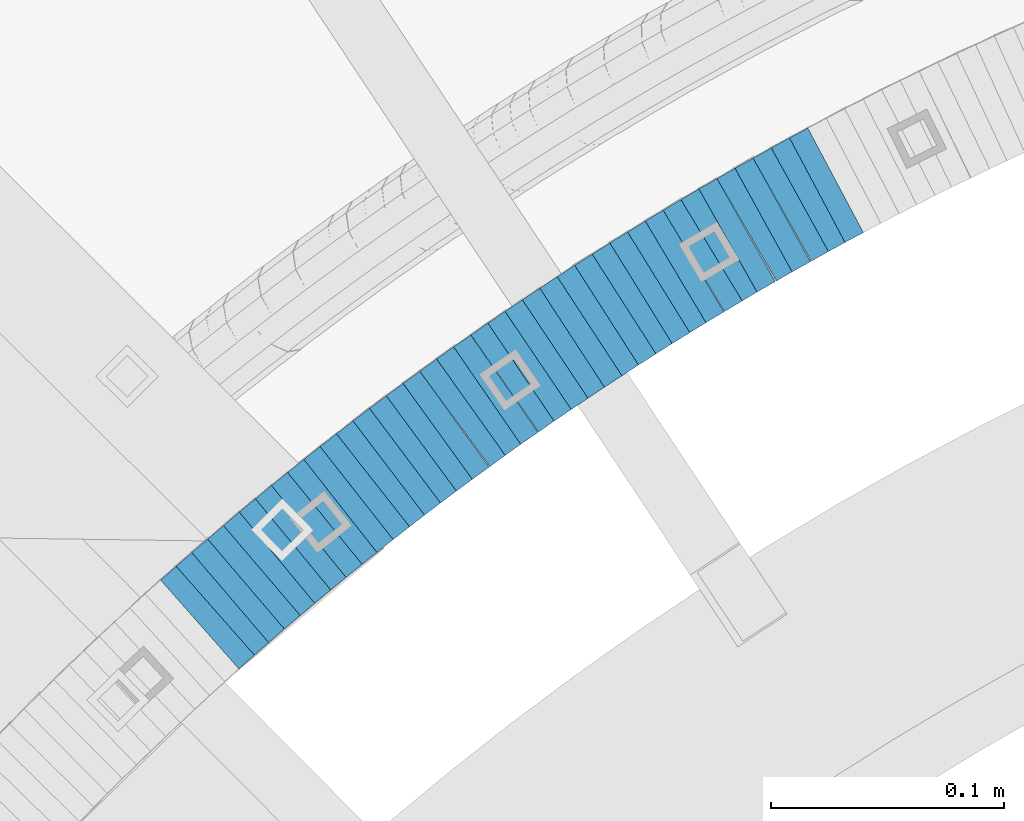
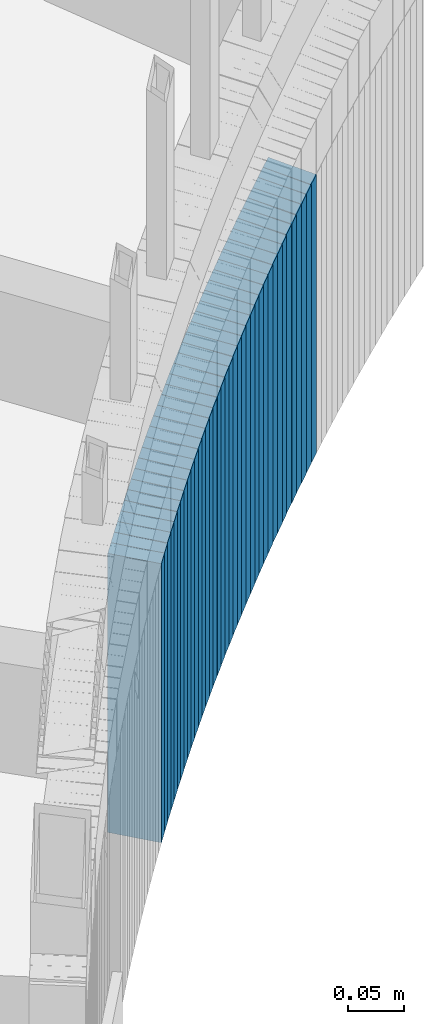
# One storey, part 897 of 975: 38 plates.
"""IFC2X3 building model written with IfcOpenShell, lengths in millimetres."""

from ifc_helpers import new_model, si_unit, frame, origin_with_axes, place, context, subcontext, project, spatial, faceted_brep, material, type_object, element, save


model = new_model("IFC2X3")

# Units and contexts
model_context = context("Model", 3, precision=1e-05, world=origin_with_axes())
body_context = subcontext(model_context, "Body", "Model", "MODEL_VIEW")
ifc_project = project(units=[si_unit("LENGTHUNIT", "METRE", prefix="MILLI"), si_unit("AREAUNIT", "SQUARE_METRE"), si_unit("VOLUMEUNIT", "CUBIC_METRE"), si_unit("MASSUNIT", "GRAM", prefix="KILO"), si_unit("TIMEUNIT", "SECOND"), si_unit("PLANEANGLEUNIT", "RADIAN"), si_unit("SOLIDANGLEUNIT", "STERADIAN"), si_unit("THERMODYNAMICTEMPERATUREUNIT", "DEGREE_CELSIUS"), si_unit("LUMINOUSINTENSITYUNIT", "LUMEN")], contexts=[model_context])

# Site, building, storey
site_placement = place(None, origin_with_axes())
site = spatial("IfcSite", under=ifc_project, at=site_placement, CompositionType="ELEMENT")
building_placement = place(site_placement, origin_with_axes())
building = spatial("IfcBuilding", under=site, at=building_placement, Name="Undefined", CompositionType="ELEMENT")
storey_placement = place(building_placement, origin_with_axes())
storey = spatial("IfcBuildingStorey", under=building, at=storey_placement, Name="Undefined", CompositionType="ELEMENT", Elevation=0.0)

# Plates
ifc_material = material(Name="STEEL/A36")
plate_type = type_object("IfcPlateType", PredefinedType="NOTDEFINED")
plate_1_placement = place(storey_placement, frame((34068.6990229387, 4631.93009048656, 613.700000000799), z_axis=(0.882970965834001, 0.469427601973053, -3.50903519574786e-11), x_axis=(0.0, 0.0, -1.0)))
element("IfcPlate", 1, at=plate_1_placement, inside=storey, type_object=plate_type, material=ifc_material, Name="WALL", context=body_context, shape_type="Brep", body=[
    faceted_brep([(0.0, -25.3999999999724, -1.81898940354586e-11), (-5.69999980926514, -25.4000000000451, 8.94986057279493), (-5.69999980926514, 25.3999999999942, 8.94986057280948), (0.0, 25.3999999999869, 1.45519152283669e-11), (299.100006103516, -25.4000000000451, 8.94986057279493), (299.100006103516, 25.3999999999942, 8.94986057280948), (304.799987792969, -25.3999999999724, -1.81898940354586e-11), (304.799987792969, 25.3999999999869, 1.45519152283669e-11)], [[[0, 1, 2, 3]], [[1, 4, 5, 2]], [[4, 6, 7, 5]], [[6, 0, 3, 7]], [[5, 7, 3, 2]], [[6, 4, 1, 0]]]),
])
plate_2_placement = place(storey_placement, frame((34061.2381867776, 4627.8137217421, 608.000000000803), z_axis=(0.875741388818649, 0.482780509041101, -7.90664671512786e-11), x_axis=(0.0, 0.0, -1.0)))
element("IfcPlate", 2, at=plate_2_placement, inside=storey, type_object=plate_type, material=ifc_material, Name="WALL", context=body_context, shape_type="Brep", body=[
    faceted_brep([(0.0, -25.3999999999724, -1.81898940354586e-11), (-5.69999980926514, -25.400000000096, 8.9140338897214), (-5.69999980926514, 25.4000000000524, 8.91403388979779), (0.0, 25.3999999999869, 1.45519152283669e-11), (299.100006103516, -25.400000000096, 8.9140338897214), (299.100006103516, 25.4000000000524, 8.91403388979779), (304.799987792969, -25.3999999999724, -1.81898940354586e-11), (304.799987792969, 25.3999999999869, 1.45519152283669e-11)], [[[0, 1, 2, 3]], [[1, 4, 5, 2]], [[4, 6, 7, 5]], [[6, 0, 3, 7]], [[5, 7, 3, 2]], [[6, 4, 1, 0]]]),
])
plate_3_placement = place(storey_placement, frame((34053.6551199948, 4623.53469993824, 602.200000000807), z_axis=(0.870978467909843, 0.491321186636015, 1.7358570403303e-10), x_axis=(0.0, 0.0, -1.0)))
element("IfcPlate", 3, at=plate_3_placement, inside=storey, type_object=plate_type, material=ifc_material, Name="WALL", context=body_context, shape_type="Brep", body=[
    faceted_brep([(0.0, -25.3999999999724, -1.81898940354586e-11), (-5.80000019073486, -25.3999999999396, 8.9627008438656), (-5.80000019073486, 25.3999999999178, 8.96270084374191), (0.0, 25.3999999999869, 1.45519152283669e-11), (299.0, -25.3999999999396, 8.9627008438656), (299.0, 25.3999999999178, 8.96270084374191), (304.799987792969, -25.3999999999724, -1.81898940354586e-11), (304.799987792969, 25.3999999999869, 1.45519152283669e-11)], [[[0, 1, 2, 3]], [[1, 4, 5, 2]], [[4, 6, 7, 5]], [[6, 0, 3, 7]], [[5, 7, 3, 2]], [[6, 4, 1, 0]]]),
])
plate_4_placement = place(storey_placement, frame((34045.638186776, 4619.113721742, 596.500000000813), z_axis=(0.875741388818649, 0.482780509041101, -7.90664671512786e-11), x_axis=(0.0, 0.0, -1.0)))
element("IfcPlate", 4, at=plate_4_placement, inside=storey, type_object=plate_type, material=ifc_material, Name="WALL", context=body_context, shape_type="Brep", body=[
    faceted_brep([(0.0, -25.3999999999724, -1.81898940354586e-11), (-5.69999980926514, -25.400000000096, 8.9140338897214), (-5.69999980926514, 25.4000000000524, 8.91403388979779), (0.0, 25.3999999999869, 1.45519152283669e-11), (299.100006103516, -25.400000000096, 8.9140338897214), (299.100006103516, 25.4000000000524, 8.91403388979779), (304.799987792969, -25.3999999999724, -1.81898940354586e-11), (304.799987792969, 25.3999999999869, 1.45519152283669e-11)], [[[0, 1, 2, 3]], [[1, 4, 5, 2]], [[4, 6, 7, 5]], [[6, 0, 3, 7]], [[5, 7, 3, 2]], [[6, 4, 1, 0]]]),
])
plate_5_placement = place(storey_placement, frame((34038.4915895317, 4614.92790563646, 590.800000000816), z_axis=(0.863371944159825, 0.504568019237926, -8.114466254483e-11), x_axis=(0.0, 0.0, -1.0)))
element("IfcPlate", 5, at=plate_5_placement, inside=storey, type_object=plate_type, material=ifc_material, Name="WALL", context=body_context, shape_type="Brep", body=[
    faceted_brep([(0.0, -25.3999999999724, -1.81898940354586e-11), (-5.69999980926514, -25.3999999999724, 8.91964149478372), (-5.69999980926514, 25.400000000016, 8.9196414947528), (0.0, 25.3999999999869, 1.45519152283669e-11), (299.100006103516, -25.3999999999724, 8.91964149478372), (299.100006103516, 25.400000000016, 8.9196414947528), (304.799987792969, -25.3999999999724, -1.81898940354586e-11), (304.799987792969, 25.3999999999869, 1.45519152283669e-11)], [[[0, 1, 2, 3]], [[1, 4, 5, 2]], [[4, 6, 7, 5]], [[6, 0, 3, 7]], [[5, 7, 3, 2]], [[6, 4, 1, 0]]]),
])
plate_6_placement = place(storey_placement, frame((34030.3551199954, 4610.33469993811, 585.100000000822), z_axis=(0.870978467909843, 0.491321186636015, 1.7358570403303e-10), x_axis=(0.0, 0.0, -1.0)))
element("IfcPlate", 6, at=plate_6_placement, inside=storey, type_object=plate_type, material=ifc_material, Name="WALL", context=body_context, shape_type="Brep", body=[
    faceted_brep([(0.0, -25.3999999999724, -1.81898940354586e-11), (-5.69999980926514, -25.4000000000087, 8.9643735885511), (-5.69999980926514, 25.4000000000669, 8.96437358860567), (0.0, 25.3999999999869, 1.45519152283669e-11), (299.100006103516, -25.4000000000087, 8.9643735885511), (299.100006103516, 25.4000000000669, 8.96437358860567), (304.799987792969, -25.3999999999724, -1.81898940354586e-11), (304.799987792969, 25.3999999999869, 1.45519152283669e-11)], [[[0, 1, 2, 3]], [[1, 4, 5, 2]], [[4, 6, 7, 5]], [[6, 0, 3, 7]], [[5, 7, 3, 2]], [[6, 4, 1, 0]]]),
])
plate_7_placement = place(storey_placement, frame((34023.2020852518, 4606.05228558063, 579.300000000827), z_axis=(0.858475095883078, 0.512855252238427, -1.68183078130824e-10), x_axis=(0.0, 0.0, -1.0)))
element("IfcPlate", 7, at=plate_7_placement, inside=storey, type_object=plate_type, material=ifc_material, Name="WALL", context=body_context, shape_type="Brep", body=[
    faceted_brep([(0.0, -25.3999999999724, -1.81898940354586e-11), (-5.80000019073486, -25.4000000000124, 8.96939277649653), (-5.80000019073486, 25.3999999999869, 8.96939277651472), (0.0, 25.3999999999869, 1.45519152283669e-11), (299.0, -25.4000000000124, 8.96939277649653), (299.0, 25.3999999999869, 8.96939277651472), (304.799987792969, -25.3999999999724, -1.81898940354586e-11), (304.799987792969, 25.3999999999869, 1.45519152283669e-11)], [[[0, 1, 2, 3]], [[1, 4, 5, 2]], [[4, 6, 7, 5]], [[6, 0, 3, 7]], [[5, 7, 3, 2]], [[6, 4, 1, 0]]]),
])
plate_8_placement = place(storey_placement, frame((34015.7277498996, 4601.52785100806, 573.600000000833), z_axis=(0.85550007890286, 0.517802679596389, 1.8612809071783e-10), x_axis=(0.0, 0.0, -1.0)))
element("IfcPlate", 8, at=plate_8_placement, inside=storey, type_object=plate_type, material=ifc_material, Name="WALL", context=body_context, shape_type="Brep", body=[
    faceted_brep([(0.0, -25.3999999999724, -1.81898940354586e-11), (-5.69999980926514, -25.4000000000669, 8.8814411163039), (-5.69999980926514, 25.400000000096, 8.88144111637848), (0.0, 25.3999999999869, 1.45519152283669e-11), (299.100006103516, -25.4000000000669, 8.8814411163039), (299.100006103516, 25.400000000096, 8.88144111637848), (304.799987792969, -25.3999999999724, -1.81898940354586e-11), (304.799987792969, 25.3999999999869, 1.45519152283669e-11)], [[[0, 1, 2, 3]], [[1, 4, 5, 2]], [[4, 6, 7, 5]], [[6, 0, 3, 7]], [[5, 7, 3, 2]], [[6, 4, 1, 0]]]),
])
plate_9_placement = place(storey_placement, frame((34007.902085253, 4596.85228558082, 567.900000000839), z_axis=(0.858475095883078, 0.512855252238427, -1.68183078130824e-10), x_axis=(0.0, 0.0, -1.0)))
element("IfcPlate", 9, at=plate_9_placement, inside=storey, type_object=plate_type, material=ifc_material, Name="WALL", context=body_context, shape_type="Brep", body=[
    faceted_brep([(0.0, -25.3999999999724, -1.81898940354586e-11), (-5.69999980926514, -25.4000000000669, 8.96939277644015), (-5.69999980926514, 25.4000000000524, 8.96939277652928), (0.0, 25.3999999999869, 1.45519152283669e-11), (299.100006103516, -25.4000000000669, 8.96939277644015), (299.100006103516, 25.4000000000524, 8.96939277652928), (304.799987792969, -25.3999999999724, -1.81898940354586e-11), (304.799987792969, 25.3999999999869, 1.45519152283669e-11)], [[[0, 1, 2, 3]], [[1, 4, 5, 2]], [[4, 6, 7, 5]], [[6, 0, 3, 7]], [[5, 7, 3, 2]], [[6, 4, 1, 0]]]),
])
plate_10_placement = place(storey_placement, frame((34000.6351821174, 4592.35476277659, 562.100000000845), z_axis=(0.850503552704234, 0.525969302181674, -1.9779372451012e-10), x_axis=(0.0, 0.0, -1.0)))
element("IfcPlate", 10, at=plate_10_placement, inside=storey, type_object=plate_type, material=ifc_material, Name="WALL", context=body_context, shape_type="Brep", body=[
    faceted_brep([(0.0, -25.3999999999724, -1.81898940354586e-11), (-5.80000019073486, -25.3999999999287, 8.93756103519445), (-5.80000019073486, 25.399999999936, 8.93756103512169), (0.0, 25.3999999999869, 1.45519152283669e-11), (299.0, -25.3999999999287, 8.93756103519445), (299.0, 25.399999999936, 8.93756103512169), (304.799987792969, -25.3999999999724, -1.81898940354586e-11), (304.799987792969, 25.3999999999869, 1.45519152283669e-11)], [[[0, 1, 2, 3]], [[1, 4, 5, 2]], [[4, 6, 7, 5]], [[6, 0, 3, 7]], [[5, 7, 3, 2]], [[6, 4, 1, 0]]]),
])
plate_11_placement = place(storey_placement, frame((33993.0351821141, 4587.65476277629, 556.400000000851), z_axis=(0.850503552704234, 0.525969302181674, -1.9779372451012e-10), x_axis=(0.0, 0.0, -1.0)))
element("IfcPlate", 11, at=plate_11_placement, inside=storey, type_object=plate_type, material=ifc_material, Name="WALL", context=body_context, shape_type="Brep", body=[
    faceted_brep([(0.0, -25.3999999999724, -1.81898940354586e-11), (-5.69999980926514, -25.4000000000415, 8.93756103511259), (-5.69999980926514, 25.4000000000815, 8.93756103522537), (0.0, 25.3999999999869, 1.45519152283669e-11), (299.100006103516, -25.4000000000415, 8.93756103511259), (299.100006103516, 25.4000000000815, 8.93756103522537), (304.799987792969, -25.3999999999724, -1.81898940354586e-11), (304.799987792969, 25.3999999999869, 1.45519152283669e-11)], [[[0, 1, 2, 3]], [[1, 4, 5, 2]], [[4, 6, 7, 5]], [[6, 0, 3, 7]], [[5, 7, 3, 2]], [[6, 4, 1, 0]]]),
])
plate_12_placement = place(storey_placement, frame((33985.6389838179, 4582.98213487769, 550.600000000854), z_axis=(0.845488902900091, 0.533992991595209, -3.59136492988909e-10), x_axis=(0.0, 0.0, -1.0)))
element("IfcPlate", 12, at=plate_12_placement, inside=storey, type_object=plate_type, material=ifc_material, Name="WALL", context=body_context, shape_type="Brep", body=[
    faceted_brep([(0.0, -25.3999999999724, -1.81898940354586e-11), (-5.80000019073486, -25.3999999999796, 8.98721313478018), (-5.80000019073486, 25.399999999936, 8.98721313473106), (0.0, 25.3999999999869, 1.45519152283669e-11), (299.0, -25.3999999999796, 8.98721313478018), (299.0, 25.399999999936, 8.98721313473106), (304.799987792969, -25.3999999999724, -1.81898940354586e-11), (304.799987792969, 25.3999999999869, 1.45519152283669e-11)], [[[0, 1, 2, 3]], [[1, 4, 5, 2]], [[4, 6, 7, 5]], [[6, 0, 3, 7]], [[5, 7, 3, 2]], [[6, 4, 1, 0]]]),
])
plate_13_placement = place(storey_placement, frame((33978.2675257215, 4578.26385943475, 544.90000000086), z_axis=(0.842271400700161, 0.539053696362977, -2.99166458717081e-10), x_axis=(0.0, 0.0, -1.0)))
element("IfcPlate", 13, at=plate_13_placement, inside=storey, type_object=plate_type, material=ifc_material, Name="WALL", context=body_context, shape_type="Brep", body=[
    faceted_brep([(0.0, -25.3999999999724, -1.81898940354586e-11), (-5.69999980926514, -25.3999999999724, 8.90224647524519), (-5.69999980926514, 25.3999999999542, 8.90224647519426), (0.0, 25.3999999999869, 1.45519152283669e-11), (299.100006103516, -25.3999999999724, 8.90224647524519), (299.100006103516, 25.3999999999542, 8.90224647519426), (304.799987792969, -25.3999999999724, -1.81898940354586e-11), (304.799987792969, 25.3999999999869, 1.45519152283669e-11)], [[[0, 1, 2, 3]], [[1, 4, 5, 2]], [[4, 6, 7, 5]], [[6, 0, 3, 7]], [[5, 7, 3, 2]], [[6, 4, 1, 0]]]),
])
plate_14_placement = place(storey_placement, frame((33970.9680558795, 4573.49353153861, 539.100000000864), z_axis=(0.837166200021127, 0.54694858400236, 6.20048012933692e-12), x_axis=(0.0, 0.0, -1.0)))
element("IfcPlate", 14, at=plate_14_placement, inside=storey, type_object=plate_type, material=ifc_material, Name="WALL", context=body_context, shape_type="Brep", body=[
    faceted_brep([(0.0, -25.3999999999724, -1.81898940354586e-11), (-5.80000019073486, -25.3999999999396, 8.9627008438656), (-5.80000019073486, 25.3999999999178, 8.96270084374191), (0.0, 25.3999999999869, 1.45519152283669e-11), (299.0, -25.3999999999396, 8.9627008438656), (299.0, 25.3999999999178, 8.96270084374191), (304.799987792969, -25.3999999999724, -1.81898940354586e-11), (304.799987792969, 25.3999999999869, 1.45519152283669e-11)], [[[0, 1, 2, 3]], [[1, 4, 5, 2]], [[4, 6, 7, 5]], [[6, 0, 3, 7]], [[5, 7, 3, 2]], [[6, 4, 1, 0]]]),
])
plate_15_placement = place(storey_placement, frame((33963.4680558794, 4568.59353153868, 533.400000000867), z_axis=(0.837166200021127, 0.54694858400236, 6.20048012933692e-12), x_axis=(0.0, 0.0, -1.0)))
element("IfcPlate", 15, at=plate_15_placement, inside=storey, type_object=plate_type, material=ifc_material, Name="WALL", context=body_context, shape_type="Brep", body=[
    faceted_brep([(0.0, -25.3999999999724, -1.81898940354586e-11), (-5.69999980926514, -25.4000000000087, 8.9643735885511), (-5.69999980926514, 25.4000000000669, 8.96437358860567), (0.0, 25.3999999999869, 1.45519152283669e-11), (299.100006103516, -25.4000000000087, 8.9643735885511), (299.100006103516, 25.4000000000669, 8.96437358860567), (304.799987792969, -25.3999999999724, -1.81898940354586e-11), (304.799987792969, 25.3999999999869, 1.45519152283669e-11)], [[[0, 1, 2, 3]], [[1, 4, 5, 2]], [[4, 6, 7, 5]], [[6, 0, 3, 7]], [[5, 7, 3, 2]], [[6, 4, 1, 0]]]),
])
plate_16_placement = place(storey_placement, frame((33956.1649468273, 4563.72347554317, 527.700000000872), z_axis=(0.832050294630691, 0.554700195785959, -1.70329258253332e-10), x_axis=(0.0, 0.0, -1.0)))
element("IfcPlate", 16, at=plate_16_placement, inside=storey, type_object=plate_type, material=ifc_material, Name="WALL", context=body_context, shape_type="Brep", body=[
    faceted_brep([(0.0, -25.3999999999724, -1.81898940354586e-11), (-5.69999980926514, -25.4000000000087, 9.01387786864507), (-5.69999980926514, 25.4000000000124, 9.0138778686669), (0.0, 25.3999999999869, 1.45519152283669e-11), (299.100006103516, -25.4000000000087, 9.01387786864507), (299.100006103516, 25.4000000000124, 9.0138778686669), (304.799987792969, -25.3999999999724, -1.81898940354586e-11), (304.799987792969, 25.3999999999869, 1.45519152283669e-11)], [[[0, 1, 2, 3]], [[1, 4, 5, 2]], [[4, 6, 7, 5]], [[6, 0, 3, 7]], [[5, 7, 3, 2]], [[6, 4, 1, 0]]]),
])
plate_17_placement = place(storey_placement, frame((33948.8959400811, 4558.8113932092, 521.900000000876), z_axis=(0.828588968904645, 0.559857410962414, -1.41944838105701e-11), x_axis=(0.0, 0.0, -1.0)))
element("IfcPlate", 17, at=plate_17_placement, inside=storey, type_object=plate_type, material=ifc_material, Name="WALL", context=body_context, shape_type="Brep", body=[
    faceted_brep([(0.0, -25.3999999999724, -1.81898940354586e-11), (-5.80000019073486, -25.399999999976, 8.9274854660398), (-5.80000019073486, 25.4000000000269, 8.92748546601433), (0.0, 25.3999999999869, 1.45519152283669e-11), (299.0, -25.399999999976, 8.9274854660398), (299.0, 25.4000000000269, 8.92748546601433), (304.799987792969, -25.3999999999724, -1.81898940354586e-11), (304.799987792969, 25.3999999999869, 1.45519152283669e-11)], [[[0, 1, 2, 3]], [[1, 4, 5, 2]], [[4, 6, 7, 5]], [[6, 0, 3, 7]], [[5, 7, 3, 2]], [[6, 4, 1, 0]]]),
])
plate_18_placement = place(storey_placement, frame((33941.4959400809, 4553.8113932095, 516.200000000881), z_axis=(0.828588968904645, 0.559857410962414, -1.41944838105701e-11), x_axis=(0.0, 0.0, -1.0)))
element("IfcPlate", 18, at=plate_18_placement, inside=storey, type_object=plate_type, material=ifc_material, Name="WALL", context=body_context, shape_type="Brep", body=[
    faceted_brep([(0.0, -25.3999999999724, -1.81898940354586e-11), (-5.69999980926514, -25.3999999999141, 8.92748546604707), (-5.69999980926514, 25.3999999999505, 8.92748546598159), (0.0, 25.3999999999869, 1.45519152283669e-11), (299.100006103516, -25.3999999999141, 8.92748546604707), (299.100006103516, 25.3999999999505, 8.92748546598159), (304.799987792969, -25.3999999999724, -1.81898940354586e-11), (304.799987792969, 25.3999999999869, 1.45519152283669e-11)], [[[0, 1, 2, 3]], [[1, 4, 5, 2]], [[4, 6, 7, 5]], [[6, 0, 3, 7]], [[5, 7, 3, 2]], [[6, 4, 1, 0]]]),
])
plate_19_placement = place(storey_placement, frame((33934.5223561921, 4548.93567091938, 510.400000000885), z_axis=(0.819759137821163, 0.572708438875056, 0.0), x_axis=(0.0, 0.0, -1.0)))
element("IfcPlate", 19, at=plate_19_placement, inside=storey, type_object=plate_type, material=ifc_material, Name="WALL", context=body_context, shape_type="Brep", body=[
    faceted_brep([(0.0, -25.3999999999724, -1.81898940354586e-11), (-5.80000019073486, -25.399999999976, 8.91066741944087), (-5.80000019073486, 25.4000000000051, 8.91066741945178), (0.0, 25.3999999999869, 1.45519152283669e-11), (299.0, -25.399999999976, 8.91066741944087), (299.0, 25.4000000000051, 8.91066741945178), (304.799987792969, -25.3999999999724, -1.81898940354586e-11), (304.799987792969, 25.3999999999869, 1.45519152283669e-11)], [[[0, 1, 2, 3]], [[1, 4, 5, 2]], [[4, 6, 7, 5]], [[6, 0, 3, 7]], [[5, 7, 3, 2]], [[6, 4, 1, 0]]]),
])
plate_20_placement = place(storey_placement, frame((33926.9893737781, 4543.74339452565, 504.700000000892), z_axis=(0.82339206675501, 0.567472910723422, 5.72463250136933e-11), x_axis=(0.0, 0.0, -1.0)))
element("IfcPlate", 20, at=plate_20_placement, inside=storey, type_object=plate_type, material=ifc_material, Name="WALL", context=body_context, shape_type="Brep", body=[
    faceted_brep([(0.0, -25.3999999999724, -1.81898940354586e-11), (-5.69999980926514, -25.3999999999724, 8.9872131347729), (-5.69999980926514, 25.3999999999833, 8.98721313475835), (0.0, 25.3999999999869, 1.45519152283669e-11), (299.100006103516, -25.3999999999724, 8.9872131347729), (299.100006103516, 25.3999999999833, 8.98721313475835), (304.799987792969, -25.3999999999724, -1.81898940354586e-11), (304.799987792969, 25.3999999999869, 1.45519152283669e-11)], [[[0, 1, 2, 3]], [[1, 4, 5, 2]], [[4, 6, 7, 5]], [[6, 0, 3, 7]], [[5, 7, 3, 2]], [[6, 4, 1, 0]]]),
])
plate_21_placement = place(storey_placement, frame((33920.0121917533, 4538.7695918113, 498.900000000897), z_axis=(0.814486661793431, 0.580182279771275, -2.11284714168869e-11), x_axis=(0.0, 0.0, -1.0)))
element("IfcPlate", 21, at=plate_21_placement, inside=storey, type_object=plate_type, material=ifc_material, Name="WALL", context=body_context, shape_type="Brep", body=[
    faceted_brep([(0.0, -25.3999999999724, -1.81898940354586e-11), (-5.80000019073486, -25.3999999999396, 8.9627008438656), (-5.80000019073486, 25.3999999999178, 8.96270084374191), (0.0, 25.3999999999869, 1.45519152283669e-11), (299.0, -25.3999999999396, 8.9627008438656), (299.0, 25.3999999999178, 8.96270084374191), (304.799987792969, -25.3999999999724, -1.81898940354586e-11), (304.799987792969, 25.3999999999869, 1.45519152283669e-11)], [[[0, 1, 2, 3]], [[1, 4, 5, 2]], [[4, 6, 7, 5]], [[6, 0, 3, 7]], [[5, 7, 3, 2]], [[6, 4, 1, 0]]]),
])
plate_22_placement = place(storey_placement, frame((33913.133124521, 4533.70199616328, 493.200000000913), z_axis=(0.805336884073592, 0.592817428177207, 3.1585841497872e-11), x_axis=(0.0, 0.0, -1.0)))
element("IfcPlate", 22, at=plate_22_placement, inside=storey, type_object=plate_type, material=ifc_material, Name="WALL", context=body_context, shape_type="Brep", body=[
    faceted_brep([(0.0, -25.3999999999724, -1.81898940354586e-11), (-5.69999980926514, -25.4000000000415, 8.93756103511259), (-5.69999980926514, 25.4000000000815, 8.93756103522537), (0.0, 25.3999999999869, 1.45519152283669e-11), (299.100006103516, -25.4000000000415, 8.93756103511259), (299.100006103516, 25.4000000000815, 8.93756103522537), (304.799987792969, -25.3999999999724, -1.81898940354586e-11), (304.799987792969, 25.3999999999869, 1.45519152283669e-11)], [[[0, 1, 2, 3]], [[1, 4, 5, 2]], [[4, 6, 7, 5]], [[6, 0, 3, 7]], [[5, 7, 3, 2]], [[6, 4, 1, 0]]]),
])
plate_23_placement = place(storey_placement, frame((33905.7470219238, 4528.36630062439, 487.500000000921), z_axis=(0.810679228188928, 0.585490554136447, 0.0), x_axis=(0.0, 0.0, -1.0)))
element("IfcPlate", 23, at=plate_23_placement, inside=storey, type_object=plate_type, material=ifc_material, Name="WALL", context=body_context, shape_type="Brep", body=[
    faceted_brep([(0.0, -25.3999999999724, -1.81898940354586e-11), (-5.69999980926514, -25.4000000000669, 8.8814411163039), (-5.69999980926514, 25.400000000096, 8.88144111637848), (0.0, 25.3999999999869, 1.45519152283669e-11), (299.100006103516, -25.4000000000669, 8.8814411163039), (299.100006103516, 25.400000000096, 8.88144111637848), (304.799987792969, -25.3999999999724, -1.81898940354586e-11), (304.799987792969, 25.3999999999869, 1.45519152283669e-11)], [[[0, 1, 2, 3]], [[1, 4, 5, 2]], [[4, 6, 7, 5]], [[6, 0, 3, 7]], [[5, 7, 3, 2]], [[6, 4, 1, 0]]]),
])
plate_24_placement = place(storey_placement, frame((33898.7331245241, 4523.20199616385, 481.700000000928), z_axis=(0.805336884073592, 0.592817428177207, 3.1585841497872e-11), x_axis=(0.0, 0.0, -1.0)))
element("IfcPlate", 24, at=plate_24_placement, inside=storey, type_object=plate_type, material=ifc_material, Name="WALL", context=body_context, shape_type="Brep", body=[
    faceted_brep([(0.0, -25.3999999999724, -1.81898940354586e-11), (-5.80000019073486, -25.3999999999287, 8.93756103519445), (-5.80000019073486, 25.399999999936, 8.93756103512169), (0.0, 25.3999999999869, 1.45519152283669e-11), (299.0, -25.3999999999287, 8.93756103519445), (299.0, 25.399999999936, 8.93756103512169), (304.799987792969, -25.3999999999724, -1.81898940354586e-11), (304.799987792969, 25.3999999999869, 1.45519152283669e-11)], [[[0, 1, 2, 3]], [[1, 4, 5, 2]], [[4, 6, 7, 5]], [[6, 0, 3, 7]], [[5, 7, 3, 2]], [[6, 4, 1, 0]]]),
])
plate_25_placement = place(storey_placement, frame((33891.7155618528, 4517.93755302095, 476.000000000932), z_axis=(0.799999999999881, 0.600000000000158, -1.28920873976312e-13), x_axis=(0.0, 0.0, -1.0)))
element("IfcPlate", 25, at=plate_25_placement, inside=storey, type_object=plate_type, material=ifc_material, Name="WALL", context=body_context, shape_type="Brep", body=[
    faceted_brep([(0.0, -25.3999999999724, -1.81898940354586e-11), (-5.69999980926514, -25.3999999999724, 9.00000000009459), (-5.69999980926514, 25.3999999999905, 8.99999999997453), (0.0, 25.3999999999869, 1.45519152283669e-11), (299.100006103516, -25.3999999999724, 9.00000000009459), (299.100006103516, 25.3999999999905, 8.99999999997453), (304.799987792969, -25.3999999999724, -1.81898940354586e-11), (304.799987792969, 25.3999999999869, 1.45519152283669e-11)], [[[0, 1, 2, 3]], [[1, 4, 5, 2]], [[4, 6, 7, 5]], [[6, 0, 3, 7]], [[5, 7, 3, 2]], [[6, 4, 1, 0]]]),
])
plate_26_placement = place(storey_placement, frame((33884.751895622, 4512.64052159118, 470.300000000939), z_axis=(0.795946119280133, 0.605367471213061, 0.0), x_axis=(0.0, 0.0, -1.0)))
element("IfcPlate", 26, at=plate_26_placement, inside=storey, type_object=plate_type, material=ifc_material, Name="WALL", context=body_context, shape_type="Brep", body=[
    faceted_brep([(0.0, -25.3999999999724, -1.81898940354586e-11), (-5.69999980926514, -25.3999999999724, 8.91964149478372), (-5.69999980926514, 25.400000000016, 8.9196414947528), (0.0, 25.3999999999869, 1.45519152283669e-11), (299.100006103516, -25.3999999999724, 8.91964149478372), (299.100006103516, 25.400000000016, 8.9196414947528), (304.799987792969, -25.3999999999724, -1.81898940354586e-11), (304.799987792969, 25.3999999999869, 1.45519152283669e-11)], [[[0, 1, 2, 3]], [[1, 4, 5, 2]], [[4, 6, 7, 5]], [[6, 0, 3, 7]], [[5, 7, 3, 2]], [[6, 4, 1, 0]]]),
])
plate_27_placement = place(storey_placement, frame((33877.8304645045, 4507.27758779248, 464.600000000941), z_axis=(0.790549812362157, 0.61239774181014, 2.36018422583583e-10), x_axis=(0.0, 0.0, -1.0)))
element("IfcPlate", 27, at=plate_27_placement, inside=storey, type_object=plate_type, material=ifc_material, Name="WALL", context=body_context, shape_type="Brep", body=[
    faceted_brep([(0.0, -25.3999999999724, -1.81898940354586e-11), (-5.69999980926514, -25.3999999999833, 8.98053455353147), (-5.69999980926514, 25.3999999999396, 8.98053455348781), (0.0, 25.3999999999869, 1.45519152283669e-11), (299.100006103516, -25.3999999999833, 8.98053455353147), (299.100006103516, 25.3999999999396, 8.98053455348781), (304.799987792969, -25.3999999999724, -1.81898940354586e-11), (304.799987792969, 25.3999999999869, 1.45519152283669e-11)], [[[0, 1, 2, 3]], [[1, 4, 5, 2]], [[4, 6, 7, 5]], [[6, 0, 3, 7]], [[5, 7, 3, 2]], [[6, 4, 1, 0]]]),
])
plate_28_placement = place(storey_placement, frame((33870.9682292721, 4501.88506721352, 458.800000000943), z_axis=(0.786318338803167, 0.61782155195641, -5.59168711333768e-11), x_axis=(0.0, 0.0, -1.0)))
element("IfcPlate", 28, at=plate_28_placement, inside=storey, type_object=plate_type, material=ifc_material, Name="WALL", context=body_context, shape_type="Brep", body=[
    faceted_brep([(0.0, -25.3999999999724, -1.81898940354586e-11), (-5.80000019073486, -25.4000000000024, 8.90224647521973), (-5.80000019073486, 25.3999999999996, 8.90224647527066), (0.0, 25.3999999999869, 1.45519152283669e-11), (299.0, -25.4000000000024, 8.90224647521973), (299.0, 25.3999999999996, 8.90224647527066), (304.799987792969, -25.3999999999724, -1.81898940354586e-11), (304.799987792969, 25.3999999999869, 1.45519152283669e-11)], [[[0, 1, 2, 3]], [[1, 4, 5, 2]], [[4, 6, 7, 5]], [[6, 0, 3, 7]], [[5, 7, 3, 2]], [[6, 4, 1, 0]]]),
])
plate_29_placement = place(storey_placement, frame((33863.9682292699, 4496.38506721333, 453.100000000948), z_axis=(0.786318338803167, 0.61782155195641, -5.59168711333768e-11), x_axis=(0.0, 0.0, -1.0)))
element("IfcPlate", 29, at=plate_29_placement, inside=storey, type_object=plate_type, material=ifc_material, Name="WALL", context=body_context, shape_type="Brep", body=[
    faceted_brep([(0.0, -25.3999999999724, -1.81898940354586e-11), (-5.69999980926514, -25.3999999999724, 8.90224647524519), (-5.69999980926514, 25.3999999999542, 8.90224647519426), (0.0, 25.3999999999869, 1.45519152283669e-11), (299.100006103516, -25.3999999999724, 8.90224647524519), (299.100006103516, 25.3999999999542, 8.90224647519426), (304.799987792969, -25.3999999999724, -1.81898940354586e-11), (304.799987792969, 25.3999999999869, 1.45519152283669e-11)], [[[0, 1, 2, 3]], [[1, 4, 5, 2]], [[4, 6, 7, 5]], [[6, 0, 3, 7]], [[5, 7, 3, 2]], [[6, 4, 1, 0]]]),
])
plate_30_placement = place(storey_placement, frame((33857.1428160734, 4490.92348527003, 447.400000000956), z_axis=(0.78086880941289, 0.6246950475921, 3.66534777640482e-10), x_axis=(0.0, 0.0, -1.0)))
element("IfcPlate", 30, at=plate_30_placement, inside=storey, type_object=plate_type, material=ifc_material, Name="WALL", context=body_context, shape_type="Brep", body=[
    faceted_brep([(0.0, -25.3999999999724, -1.81898940354586e-11), (-5.69999980926514, -25.4000000000087, 8.9643735885511), (-5.69999980926514, 25.4000000000669, 8.96437358860567), (0.0, 25.3999999999869, 1.45519152283669e-11), (299.100006103516, -25.4000000000087, 8.9643735885511), (299.100006103516, 25.4000000000669, 8.96437358860567), (304.799987792969, -25.3999999999724, -1.81898940354586e-11), (304.799987792969, 25.3999999999869, 1.45519152283669e-11)], [[[0, 1, 2, 3]], [[1, 4, 5, 2]], [[4, 6, 7, 5]], [[6, 0, 3, 7]], [[5, 7, 3, 2]], [[6, 4, 1, 0]]]),
])
plate_31_placement = place(storey_placement, frame((33850.3818516118, 4485.43551742379, 441.600000000961), z_axis=(0.776458094254318, 0.630168888367993, -8.04775481810794e-11), x_axis=(0.0, 0.0, -1.0)))
element("IfcPlate", 31, at=plate_31_placement, inside=storey, type_object=plate_type, material=ifc_material, Name="WALL", context=body_context, shape_type="Brep", body=[
    faceted_brep([(0.0, -25.3999999999724, -1.81898940354586e-11), (-5.80000019073486, -25.3999999999542, 8.88650703432359), (-5.80000019073486, 25.4000000000233, 8.88650703432359), (0.0, 25.3999999999869, 1.45519152283669e-11), (299.0, -25.3999999999542, 8.88650703432359), (299.0, 25.4000000000233, 8.88650703432359), (304.799987792969, -25.3999999999724, -1.81898940354586e-11), (304.799987792969, 25.3999999999869, 1.45519152283669e-11)], [[[0, 1, 2, 3]], [[1, 4, 5, 2]], [[4, 6, 7, 5]], [[6, 0, 3, 7]], [[5, 7, 3, 2]], [[6, 4, 1, 0]]]),
])
for number, where, z_axis, x_axis, name in (
    (32, (33843.652350598, 4479.87512452484, 435.900000000968), (0.77096175158008, 0.636881447053198, -1.96447672351497e-10), (0.0, 0.0, -1.0), "WALL"),
    (33, (33836.7523505971, 4474.17512452497, 430.200000000974), (0.77096175158008, 0.636881447053198, -1.96447672351497e-10), (0.0, 0.0, -1.0), "WALL"),
):
    element("IfcPlate", number, at=place(storey_placement, frame(where, z_axis=z_axis, x_axis=x_axis)), inside=storey, type_object=plate_type, material=ifc_material, Name=name, context=body_context, shape_type="Brep", body=[
        faceted_brep([(0.0, -25.3999999999724, -1.81898940354586e-11), (-5.69999980926514, -25.4000000000451, 8.94986057279493), (-5.69999980926514, 25.3999999999942, 8.94986057280948), (0.0, 25.3999999999869, 1.45519152283669e-11), (299.100006103516, -25.4000000000451, 8.94986057279493), (299.100006103516, 25.3999999999942, 8.94986057280948), (304.799987792969, -25.3999999999724, -1.81898940354586e-11), (304.799987792969, 25.3999999999869, 1.45519152283669e-11)], [[[0, 1, 2, 3]], [[1, 4, 5, 2]], [[4, 6, 7, 5]], [[6, 0, 3, 7]], [[5, 7, 3, 2]], [[6, 4, 1, 0]]]),
    ])
plate_32_placement = place(storey_placement, frame((33830.2588056418, 4468.63237063906, 424.400000000979), z_axis=(0.760833952036961, 0.648946605991447, 1.94459062186069e-11), x_axis=(0.0, 0.0, -1.0)))
element("IfcPlate", 34, at=plate_32_placement, inside=storey, type_object=plate_type, material=ifc_material, Name="WALL", context=body_context, shape_type="Brep", body=[
    faceted_brep([(0.0, -25.3999999999724, -1.81898940354586e-11), (-5.80000019073486, -25.3999999999287, 8.93756103519445), (-5.80000019073486, 25.399999999936, 8.93756103512169), (0.0, 25.3999999999869, 1.45519152283669e-11), (299.0, -25.3999999999287, 8.93756103519445), (299.0, 25.399999999936, 8.93756103512169), (304.799987792969, -25.3999999999724, -1.81898940354586e-11), (304.799987792969, 25.3999999999869, 1.45519152283669e-11)], [[[0, 1, 2, 3]], [[1, 4, 5, 2]], [[4, 6, 7, 5]], [[6, 0, 3, 7]], [[5, 7, 3, 2]], [[6, 4, 1, 0]]]),
])
for number, where, z_axis, x_axis, name in (
    (35, (33823.4588056429, 4462.83237063921, 418.700000000987), (0.760833952036961, 0.648946605991447, 1.94459062186069e-11), (0.0, 0.0, -1.0), "WALL"),
    (36, (33816.6588056439, 4457.03237063915, 413.000000000993), (0.760833952036961, 0.648946605991447, 1.94459062186069e-11), (0.0, 0.0, -1.0), "WALL"),
):
    element("IfcPlate", number, at=place(storey_placement, frame(where, z_axis=z_axis, x_axis=x_axis)), inside=storey, type_object=plate_type, material=ifc_material, Name=name, context=body_context, shape_type="Brep", body=[
        faceted_brep([(0.0, -25.3999999999724, -1.81898940354586e-11), (-5.69999980926514, -25.4000000000415, 8.93756103511259), (-5.69999980926514, 25.4000000000815, 8.93756103522537), (0.0, 25.3999999999869, 1.45519152283669e-11), (299.100006103516, -25.4000000000415, 8.93756103511259), (299.100006103516, 25.4000000000815, 8.93756103522537), (304.799987792969, -25.3999999999724, -1.81898940354586e-11), (304.799987792969, 25.3999999999869, 1.45519152283669e-11)], [[[0, 1, 2, 3]], [[1, 4, 5, 2]], [[4, 6, 7, 5]], [[6, 0, 3, 7]], [[5, 7, 3, 2]], [[6, 4, 1, 0]]]),
    ])
plate_33_placement = place(storey_placement, frame((33810.261923203, 4451.39507488583, 407.300000000998), z_axis=(0.750491265210853, 0.660880368026025, 7.65005552239016e-11), x_axis=(0.0, 0.0, -1.0)))
element("IfcPlate", 37, at=plate_33_placement, inside=storey, type_object=plate_type, material=ifc_material, Name="WALL", context=body_context, shape_type="Brep", body=[
    faceted_brep([(0.0, -25.3999999999724, -1.81898940354586e-11), (-5.69999980926514, -25.3999999999141, 8.92748546604707), (-5.69999980926514, 25.3999999999505, 8.92748546598159), (0.0, 25.3999999999869, 1.45519152283669e-11), (299.100006103516, -25.3999999999141, 8.92748546604707), (299.100006103516, 25.3999999999505, 8.92748546598159), (304.799987792969, -25.3999999999724, -1.81898940354586e-11), (304.799987792969, 25.3999999999869, 1.45519152283669e-11)], [[[0, 1, 2, 3]], [[1, 4, 5, 2]], [[4, 6, 7, 5]], [[6, 0, 3, 7]], [[5, 7, 3, 2]], [[6, 4, 1, 0]]]),
])
plate_34_placement = place(storey_placement, frame((33803.5619232048, 4445.49507488592, 401.500000001004), z_axis=(0.750491265210853, 0.660880368026025, 7.65005552239016e-11), x_axis=(0.0, 0.0, -1.0)))
element("IfcPlate", 38, at=plate_34_placement, inside=storey, type_object=plate_type, material=ifc_material, Name="WALL", context=body_context, shape_type="Brep", body=[
    faceted_brep([(0.0, -25.3999999999724, -1.81898940354586e-11), (-5.80000019073486, -25.399999999976, 8.9274854660398), (-5.80000019073486, 25.4000000000269, 8.92748546601433), (0.0, 25.3999999999869, 1.45519152283669e-11), (299.0, -25.399999999976, 8.9274854660398), (299.0, 25.4000000000269, 8.92748546601433), (304.799987792969, -25.3999999999724, -1.81898940354586e-11), (304.799987792969, 25.3999999999869, 1.45519152283669e-11)], [[[0, 1, 2, 3]], [[1, 4, 5, 2]], [[4, 6, 7, 5]], [[6, 0, 3, 7]], [[5, 7, 3, 2]], [[6, 4, 1, 0]]]),
])

save(model, "model.ifc")
